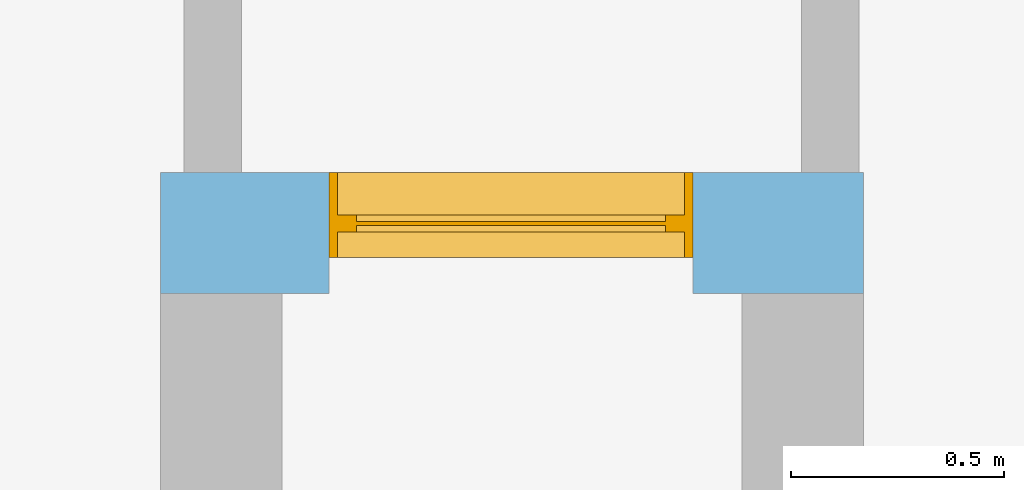
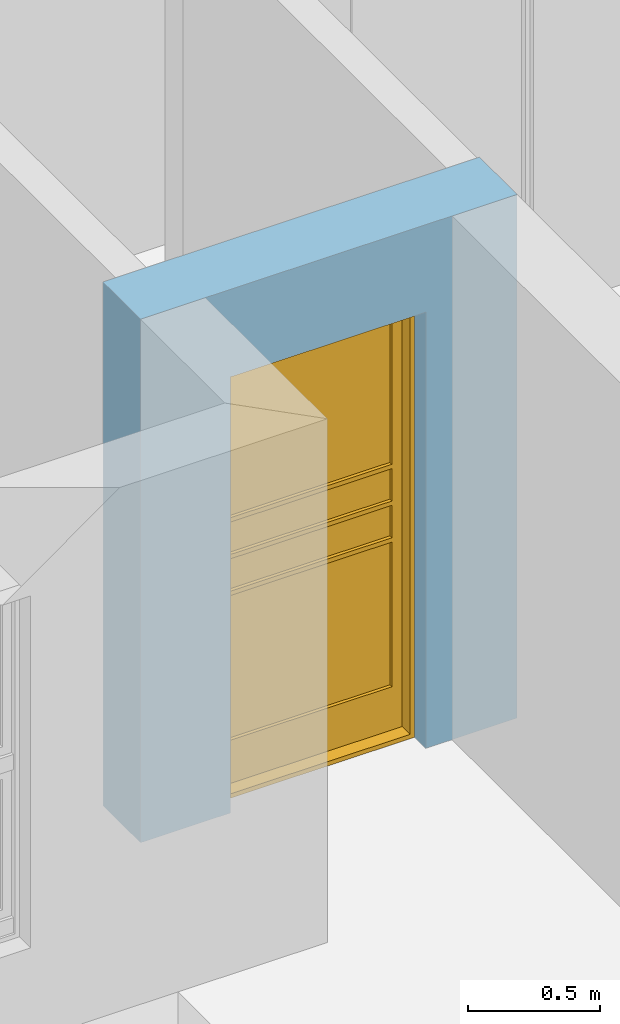
# One storey, part 9 of 15: 1 window, 1 opening, plus 1 element that does not belong to this part.
"""IFC4 building model written with IfcOpenShell, lengths in millimetres."""

from ifc_helpers import new_model, entity, si_unit, converted_unit, frame, origin_with_axes, origin_2d_with_axis, place, context, subcontext, project, spatial, line, indexed_curve, outline, extrude, polygons, source, transform, mapped, material, layer, layer_set, layer_usage, type_object, type_shapes, element, fill, save


model = new_model("IFC4")

# Units and contexts
model_context = context("Model", 3, precision=1e-05, world=origin_with_axes())
plan_context = context("Plan", 2, precision=1e-05, world=origin_2d_with_axis())
body_context = subcontext(model_context, "Body", "Model", "MODEL_VIEW")
ifc_project = project(units=[si_unit("VOLUMEUNIT", "CUBIC_METRE"), si_unit("LENGTHUNIT", "METRE", prefix="MILLI"), converted_unit("PLANEANGLEUNIT", "degree", entity("IfcReal", 0.0174532925199433), si_unit("PLANEANGLEUNIT", "RADIAN"), dimensions=[0, 0, 0, 0, 0, 0, 0]), si_unit("AREAUNIT", "SQUARE_METRE")], contexts=[model_context, plan_context])

# Site, building, storey
site_placement = place(None, origin_with_axes())
site = spatial("IfcSite", under=ifc_project, at=site_placement)
building_placement = place(site_placement, origin_with_axes())
building = spatial("IfcBuilding", under=site, at=building_placement, Name="Building")
storey_placement = place(building_placement, origin_with_axes())
storey = spatial("IfcBuildingStorey", under=building, at=storey_placement, Name="EXISTING")

# Wall, opening, window
ifc_material = material()
ifc_layer = layer(ifc_material, 285.0, Name="brick")
ifc_layer_set = layer_set([ifc_layer])
ifc_layer_usage = layer_usage(ifc_layer_set, "AXIS2", "POSITIVE", 0.0)
wall_type = type_object("IfcWallType", Name="285mm Wall", PredefinedType="STANDARD", material=ifc_layer_set)
wall_placement = place(storey_placement, frame((4229.12073135376, -768.332958221436, 0.0), z_axis=(0.0, 0.0, 1.0), x_axis=(0.999999999999972, -2.38418579101556e-07, 0.0)))
wall = element("IfcWall", 1, at=wall_placement, inside=storey, type_object=wall_type, material=ifc_layer_usage, Name="Wall", context=body_context, shape_type="SweptSolid", body=[
    extrude(outline(indexed_curve([(0.0, 0.0), (0.0, 285.0), (1649.9991590325, 285.0), (1649.9991590325, 0.0), (0.0, 0.0)], self_intersect=False)), origin_with_axes(), (0.0, 0.0, 1.0), 2425.00019073486),
])
shared_shape_1 = source(origin_with_axes(), body_context, "Body", "SweptSolid", [
    extrude(outline(indexed_curve([(0.0, 0.0), (855.007202148438, 0.0), (855.007202148438, 2020.00012207031), (0.0, 2020.00012207031)], segments=[line(1, 2, 3, 4, 1)])), frame((1.34110436533774e-07, -600.0, 0.0), z_axis=(0.0, -1.0, 0.0), x_axis=(1.0, 0.0, 0.0)), (0.0, 0.0, -1.0), 1200.0),
])
opening_placement = place(wall_placement, frame((1250.00807848092, 170.333112282545, 0.0), z_axis=(0.0, 0.0, 1.0), x_axis=(-0.999999999999989, 1.50995788317222e-07, 0.0)))
opening = element("IfcOpeningElement", 2, at=opening_placement, cuts=wall, PredefinedType="OPENING", context=body_context, shape_type="MappedRepresentation", body=[
    mapped(shared_shape_1, transform((0.0, 0.0, 0.0), x_axis=(1.0, 0.0, 0.0), y_axis=(0.0, 1.0, 0.0), z_axis=(0.0, 0.0, 1.0), scale=1.0)),
])
window_type = type_object("IfcWindowType", Name="Ex.855x2020", PartitioningType="NOTDEFINED", PredefinedType="WINDOW")
shared_shape_2 = source(origin_with_axes(), body_context, "Body", "Tessellation", [
    polygons([(855.00537109375, -114.666618347168, 0.0), (855.00537109375, -114.666618347168, 19.999979019165), (0.000134110436192714, -114.66674041748, 0.0), (0.000134110436192714, -114.66674041748, 19.999979019165), (855.00537109375, 85.3333587646484, 0.0), (855.00537109375, 85.3333587646484, 19.999979019165), (0.000134110436192714, 85.3332672119141, 0.0), (0.000134110436192714, 85.3332672119141, 19.999979019165), (0.00204145885072649, -114.666618347168, 19.999979019165), (20.002498626709, -114.666618347168, 19.999979019165), (0.00204145885072649, -114.66674041748, 2000.00012207031), (20.002498626709, -114.66674041748, 2000.00012207031), (0.00204145885072649, 85.3333587646484, 19.999979019165), (20.002498626709, 85.3333587646484, 19.999979019165), (0.00204145885072649, 85.3332672119141, 2000.00012207031), (20.002498626709, 85.3332672119141, 2000.00012207031), (835.004943847656, -114.666618347168, 19.999979019165), (855.00537109375, -114.666618347168, 19.999979019165), (835.004943847656, -114.66674041748, 2000.00012207031), (855.00537109375, -114.66674041748, 2000.00012207031), (835.004943847656, 85.3333587646484, 19.999979019165), (855.00537109375, 85.3333587646484, 19.999979019165), (835.004943847656, 85.3332672119141, 2000.00012207031), (855.00537109375, 85.3332672119141, 2000.00012207031), (855.00732421875, -114.666618347168, 2000.00012207031), (855.00732421875, -114.666618347168, 2020.00012207031), (0.00204145885072649, -114.66674041748, 2000.00012207031), (0.00204145885072649, -114.66674041748, 2020.00012207031), (855.00732421875, 85.3333587646484, 2000.00012207031), (855.00732421875, 85.3333587646484, 2020.00012207031), (0.00204145885072649, 85.3332672119141, 2000.00012207031), (0.00204145885072649, 85.3332672119141, 2020.00012207031), (65.002571105957, -14.666690826416, 1955.00146484375), (20.002498626709, -14.6666603088379, 1955.00146484375), (65.002571105957, -14.6666603088379, 220.002517700195), (20.002498626709, -14.6666603088379, 220.002517700195), (65.002571105957, 25.3332996368408, 1955.00146484375), (20.002498626709, 25.3333282470703, 1955.00146484375), (65.002571105957, 25.3333282470703, 220.002517700195), (20.002498626709, 25.3333282470703, 220.002517700195), (835.003051757812, -14.6665716171265, 20.0024833679199), (835.003051757812, -14.6665716171265, 220.001449584961), (20.0044059753418, -14.6666603088379, 20.0034370422363), (20.0044059753418, -14.6666603088379, 220.002395629883), (835.003051757812, 25.3334178924561, 20.0024833679199), (835.003051757812, 25.3334178924561, 220.001449584961), (20.0044059753418, 25.3333282470703, 20.0034370422363), (20.0044059753418, 25.3333282470703, 220.002395629883), (835.004943847656, -14.666690826416, 1955.0009765625), (790.0048828125, -14.6666603088379, 1955.0009765625), (835.004943847656, -14.6666603088379, 220.002395629883), (790.0048828125, -14.6666603088379, 220.002395629883), (835.004943847656, 25.3332996368408, 1955.0009765625), (790.0048828125, 25.3333282470703, 1955.0009765625), (835.004943847656, 25.3333282470703, 220.002395629883), (790.0048828125, 25.3333282470703, 220.002395629883), (835.003051757812, -14.6665716171265, 1955.00024414062), (835.003051757812, -14.6665716171265, 2000.00012207031), (20.0044059753418, -14.6666603088379, 1955.00122070312), (20.0044059753418, -14.6666603088379, 2000.00109863281), (835.003051757812, 25.3334178924561, 1955.00024414062), (835.003051757812, 25.3334178924561, 2000.00012207031), (20.0044059753418, 25.3333282470703, 1955.00122070312), (20.0044059753418, 25.3333282470703, 2000.00109863281), (790.0029296875, -14.6665716171265, 1230.00207519531), (790.0029296875, -14.6665716171265, 1250.00158691406), (65.002571105957, -14.6666603088379, 1230.00244140625), (65.002571105957, -14.6666603088379, 1250.00207519531), (790.0029296875, 25.3334178924561, 1230.00207519531), (790.0029296875, 25.3334178924561, 1250.00158691406), (65.002571105957, 25.3333282470703, 1230.00244140625), (65.002571105957, 25.3333282470703, 1250.00207519531), (790.0029296875, -14.6665716171265, 1060.00219726562), (790.0029296875, -14.6665716171265, 1080.00158691406), (65.002571105957, -14.6666603088379, 1060.00244140625), (65.002571105957, -14.6666603088379, 1080.00207519531), (790.0029296875, 25.3334178924561, 1060.00219726562), (790.0029296875, 25.3334178924561, 1080.00158691406), (65.002571105957, 25.3333282470703, 1060.00244140625), (65.002571105957, 25.3333282470703, 1080.00207519531), (790.0029296875, -14.6665716171265, 890.002197265625), (790.0029296875, -14.6665716171265, 910.001708984375), (65.002571105957, -14.6666603088379, 890.00244140625), (65.002571105957, -14.6666603088379, 910.002197265625), (790.0029296875, 25.3334178924561, 890.002197265625), (790.0029296875, 25.3334178924561, 910.001708984375), (65.002571105957, 25.3333282470703, 890.00244140625), (65.002571105957, 25.3333282470703, 910.002197265625), (790.0029296875, 0.333324044942856, 1955.00122070312), (65.0006637573242, 0.333324044942856, 1955.00122070312), (790.001037597656, 0.333324044942856, 1250.00207519531), (65.0006637573242, 0.333324044942856, 1250.00207519531), (790.0029296875, 10.3333139419556, 1955.00122070312), (65.0006637573242, 10.3333139419556, 1955.00122070312), (790.001037597656, 10.3333139419556, 1250.00207519531), (65.0006637573242, 10.3333139419556, 1250.00207519531), (790.0029296875, 0.333324044942856, 890.002197265625), (65.0006637573242, 0.333324044942856, 890.001953125), (790.001037597656, 0.333324044942856, 220.001983642578), (65.0006637573242, 0.333324044942856, 220.002044677734), (790.0029296875, 10.3333139419556, 890.002197265625), (65.0006637573242, 10.3333139419556, 890.001953125), (790.001037597656, 10.3333139419556, 220.001983642578), (65.0006637573242, 10.3333139419556, 220.002044677734), (790.001037597656, 0.333324044942856, 1230.001953125), (65.0006637573242, 0.333324044942856, 1230.001953125), (790.001037597656, 0.333324044942856, 1080.00158691406), (65.0006637573242, 0.333324044942856, 1080.00158691406), (790.001037597656, 10.3333139419556, 1230.001953125), (65.0006637573242, 10.3333139419556, 1230.001953125), (790.001037597656, 10.3333139419556, 1080.00158691406), (65.0006637573242, 10.3333139419556, 1080.00158691406), (790.001037597656, 0.333324044942856, 1060.00244140625), (65.0006637573242, 0.333324044942856, 1060.00256347656), (790.001037597656, 0.333324044942856, 910.002197265625), (65.0006637573242, 0.333324044942856, 910.002197265625), (790.001037597656, 10.3333139419556, 1060.00244140625), (65.0006637573242, 10.3333139419556, 1060.00256347656), (790.001037597656, 10.3333139419556, 910.002197265625), (65.0006637573242, 10.3333139419556, 910.002197265625)], [[[1, 2, 4, 3]], [[3, 4, 8, 7]], [[7, 8, 6, 5]], [[5, 6, 2, 1]], [[3, 7, 5, 1]], [[8, 4, 2, 6]], [[9, 10, 12, 11]], [[11, 12, 16, 15]], [[15, 16, 14, 13]], [[13, 14, 10, 9]], [[11, 15, 13, 9]], [[16, 12, 10, 14]], [[17, 18, 20, 19]], [[19, 20, 24, 23]], [[23, 24, 22, 21]], [[21, 22, 18, 17]], [[19, 23, 21, 17]], [[24, 20, 18, 22]], [[25, 26, 28, 27]], [[27, 28, 32, 31]], [[31, 32, 30, 29]], [[29, 30, 26, 25]], [[27, 31, 29, 25]], [[32, 28, 26, 30]], [[33, 34, 36, 35]], [[35, 36, 40, 39]], [[39, 40, 38, 37]], [[37, 38, 34, 33]], [[35, 39, 37, 33]], [[40, 36, 34, 38]], [[41, 42, 44, 43]], [[43, 44, 48, 47]], [[47, 48, 46, 45]], [[45, 46, 42, 41]], [[43, 47, 45, 41]], [[48, 44, 42, 46]], [[49, 50, 52, 51]], [[51, 52, 56, 55]], [[55, 56, 54, 53]], [[53, 54, 50, 49]], [[51, 55, 53, 49]], [[56, 52, 50, 54]], [[57, 58, 60, 59]], [[59, 60, 64, 63]], [[63, 64, 62, 61]], [[61, 62, 58, 57]], [[59, 63, 61, 57]], [[64, 60, 58, 62]], [[65, 66, 68, 67]], [[67, 68, 72, 71]], [[71, 72, 70, 69]], [[69, 70, 66, 65]], [[67, 71, 69, 65]], [[72, 68, 66, 70]], [[73, 74, 76, 75]], [[75, 76, 80, 79]], [[79, 80, 78, 77]], [[77, 78, 74, 73]], [[75, 79, 77, 73]], [[80, 76, 74, 78]], [[81, 82, 84, 83]], [[83, 84, 88, 87]], [[87, 88, 86, 85]], [[85, 86, 82, 81]], [[83, 87, 85, 81]], [[88, 84, 82, 86]], [[89, 90, 92, 91]], [[91, 92, 96, 95]], [[95, 96, 94, 93]], [[93, 94, 90, 89]], [[91, 95, 93, 89]], [[96, 92, 90, 94]], [[97, 98, 100, 99]], [[99, 100, 104, 103]], [[103, 104, 102, 101]], [[101, 102, 98, 97]], [[99, 103, 101, 97]], [[104, 100, 98, 102]], [[105, 106, 108, 107]], [[107, 108, 112, 111]], [[111, 112, 110, 109]], [[109, 110, 106, 105]], [[107, 111, 109, 105]], [[112, 108, 106, 110]], [[113, 114, 116, 115]], [[115, 116, 120, 119]], [[119, 120, 118, 117]], [[117, 118, 114, 113]], [[115, 119, 117, 113]], [[120, 116, 114, 118]]], closed=True),
])
type_shapes(window_type, [shared_shape_2])
window_placement = place(opening_placement, frame((1.28598101056809e-05, -9.43729758784428e-05, 0.0), z_axis=(0.0, 0.0, 1.0), x_axis=(1.0, 5.77041195316992e-21, 0.0)))
window = element("IfcWindow", 3, at=window_placement, inside=storey, type_object=window_type, Name="Window", context=body_context, shape_type="MappedRepresentation", body=[
    mapped(shared_shape_2, transform((0.0, 0.0, 0.0), x_axis=(1.0, 0.0, 0.0), y_axis=(0.0, 1.0, 0.0), z_axis=(0.0, 0.0, 1.0), scale=1.0)),
])
fill(opening, window)

save(model, "model.ifc")
